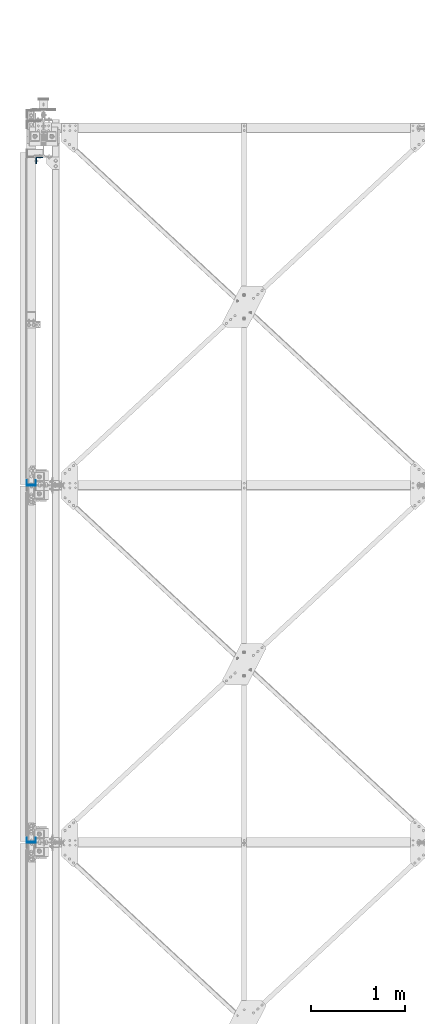
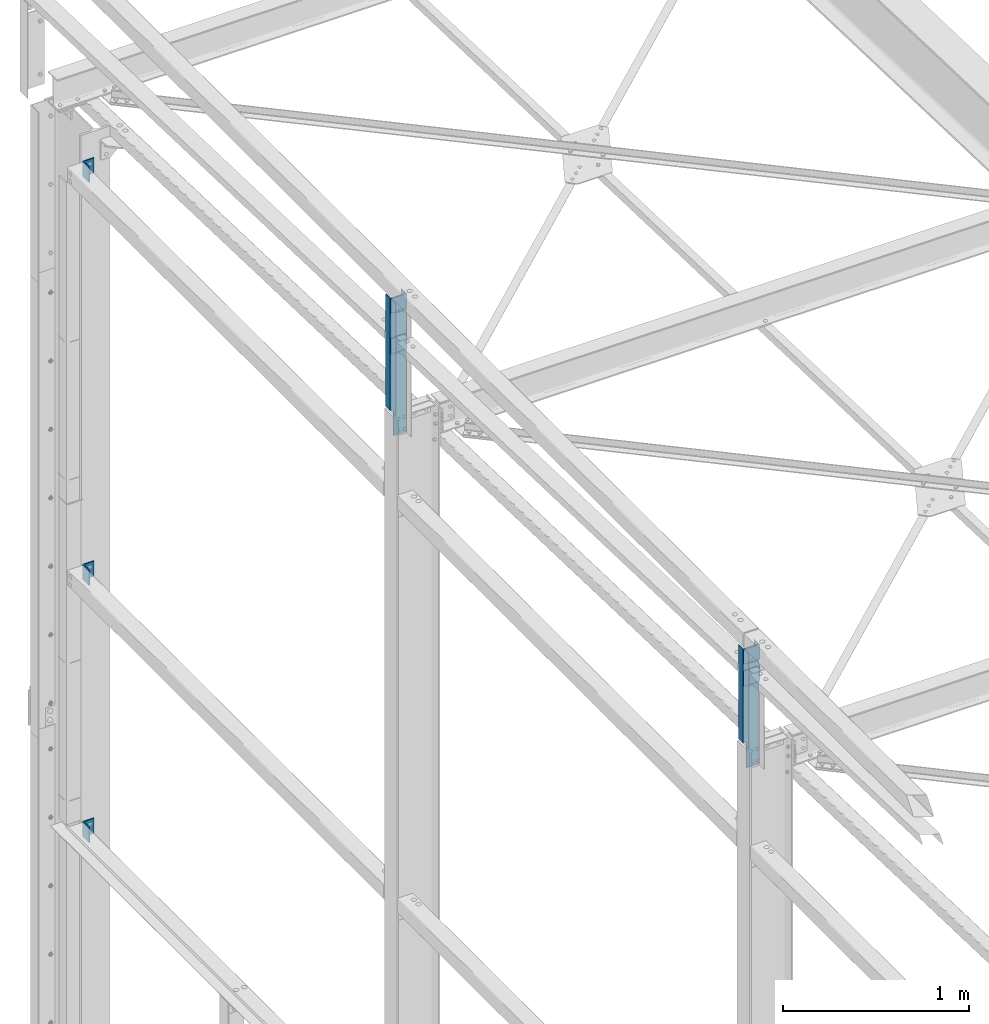
# One storey, part 23 of 496: 9 columns, 9 elements without a shape of their own.
"""IFC2X3 building model written with IfcOpenShell, lengths in millimetres."""

from ifc_helpers import new_model, si_unit, frame, origin_with_axes, origin_2d_with_axis, place, context, subcontext, project, spatial, polyline, rectangle, l_section, u_section, outline, extrude, boolean, material, type_object, element, aggregate, save


model = new_model("IFC2X3")

# Units and contexts
model_context = context("Model", 3, precision=1e-05, world=origin_with_axes())
body_context = subcontext(model_context, "Body", "Model", "MODEL_VIEW")
ifc_project = project(units=[si_unit("LENGTHUNIT", "METRE", prefix="MILLI"), si_unit("AREAUNIT", "SQUARE_METRE"), si_unit("VOLUMEUNIT", "CUBIC_METRE"), si_unit("MASSUNIT", "GRAM", prefix="KILO"), si_unit("TIMEUNIT", "SECOND"), si_unit("PLANEANGLEUNIT", "RADIAN"), si_unit("SOLIDANGLEUNIT", "STERADIAN"), si_unit("THERMODYNAMICTEMPERATUREUNIT", "DEGREE_CELSIUS"), si_unit("LUMINOUSINTENSITYUNIT", "LUMEN")], contexts=[model_context])

# Site, building, storey
site_placement = place(None, origin_with_axes())
site = spatial("IfcSite", under=ifc_project, at=site_placement, CompositionType="ELEMENT")
building_placement = place(site_placement, origin_with_axes())
building = spatial("IfcBuilding", under=site, at=building_placement, Name="Undefined", CompositionType="ELEMENT")
storey_placement = place(building_placement, origin_with_axes())
storey = spatial("IfcBuildingStorey", under=building, at=storey_placement, Name="Undefined", CompositionType="ELEMENT", Elevation=0.0)

# Assembly, column
assembly_1_placement = place(storey_placement, origin_with_axes())
assembly_1 = element("IfcElementAssembly", 1, at=assembly_1_placement, inside=storey, AssemblyPlace="NOTDEFINED", PredefinedType="NOTDEFINED")
ifc_material = material(Name="Undefined/S235-E24")
column_type_1 = type_object("IfcColumnType", PredefinedType="NOTDEFINED")
column_1_placement = place(assembly_1_placement, frame((-45.0000013899306, 14855.0031007332, 7100.00005189506), z_axis=(0.0, 0.0, 1.0), x_axis=(0.0, -1.0, 0.0)))
column_1 = element("IfcColumn", 2, at=column_1_placement, type_object=column_type_1, material=ifc_material, context=body_context, shape_type="SweptSolid", body=[
    extrude(l_section(Depth=70.0, Width=70.0, Thickness=7.0, FilletRadius=9.0, EdgeRadius=4.5, at=origin_2d_with_axis()), frame((0.0, 0.0, 100.0), z_axis=(0.0, 0.0, -1.0), x_axis=(0.0, 1.0, 0.0)), (0.0, 0.0, 1.0), 100.0),
])
aggregate(assembly_1, [column_1])

assembly_2_placement = place(storey_placement, origin_with_axes())
assembly_2 = element("IfcElementAssembly", 3, at=assembly_2_placement, inside=storey, AssemblyPlace="NOTDEFINED", PredefinedType="NOTDEFINED")
column_2_placement = place(assembly_2_placement, frame((-45.0000013899306, 14855.0031513532, 2760.0000275648), z_axis=(0.0, 0.0, 1.0), x_axis=(0.0, -1.0, 0.0)))
column_2 = element("IfcColumn", 4, at=column_2_placement, type_object=column_type_1, material=ifc_material, context=body_context, shape_type="SweptSolid", body=[
    extrude(l_section(Depth=70.0, Width=70.0, Thickness=7.0, FilletRadius=9.0, EdgeRadius=4.5, at=origin_2d_with_axis()), frame((0.0, 0.0, 100.0), z_axis=(0.0, 0.0, -1.0), x_axis=(0.0, 1.0, 0.0)), (0.0, 0.0, 1.0), 100.0),
])
aggregate(assembly_2, [column_2])

assembly_3_placement = place(storey_placement, origin_with_axes())
assembly_3 = element("IfcElementAssembly", 5, at=assembly_3_placement, inside=storey, AssemblyPlace="NOTDEFINED", PredefinedType="NOTDEFINED")
column_3_placement = place(assembly_3_placement, frame((-45.0000013899306, 14855.0031378332, 4450.00002768), z_axis=(0.0, 0.0, 1.0), x_axis=(0.0, -1.0, 0.0)))
column_3 = element("IfcColumn", 6, at=column_3_placement, type_object=column_type_1, material=ifc_material, context=body_context, shape_type="SweptSolid", body=[
    extrude(l_section(Depth=70.0, Width=70.0, Thickness=7.0, FilletRadius=9.0, EdgeRadius=4.5, at=origin_2d_with_axis()), frame((0.0, 0.0, 100.0), z_axis=(0.0, 0.0, -1.0), x_axis=(0.0, 1.0, 0.0)), (0.0, 0.0, 1.0), 100.0),
])
aggregate(assembly_3, [column_3])

assembly_4_placement = place(storey_placement, origin_with_axes())
assembly_4 = element("IfcElementAssembly", 7, at=assembly_4_placement, inside=storey, AssemblyPlace="NOTDEFINED", PredefinedType="NOTDEFINED")
column_type_2 = type_object("IfcColumnType", PredefinedType="NOTDEFINED")
column_4_placement = place(assembly_4_placement, frame((-129.999997908177, 11400.0000000298, 8082.99636005339), z_axis=(0.0, 0.0, 1.0), x_axis=(-1.0, 0.0, 0.0)))
column_4 = element("IfcColumn", 8, at=column_4_placement, type_object=column_type_2, material=ifc_material, context=body_context, shape_type="SweptSolid", body=[
    extrude(rectangle(XDim=6.0, YDim=100.0, at=origin_2d_with_axis()), frame((0.0, 0.0, 100.0), z_axis=(0.0, 0.0, -1.0), x_axis=(0.0, 1.0, 0.0)), (0.0, 0.0, 1.0), 100.0),
])
aggregate(assembly_4, [column_4])

assembly_5_placement = place(storey_placement, origin_with_axes())
assembly_5 = element("IfcElementAssembly", 9, at=assembly_5_placement, inside=storey, AssemblyPlace="NOTDEFINED", PredefinedType="NOTDEFINED")
column_5_placement = place(assembly_5_placement, frame((-129.999997908177, 7600.00000002978, 8202.43), z_axis=(0.0, 0.0, 1.0), x_axis=(-1.0, 0.0, 0.0)))
column_5 = element("IfcColumn", 10, at=column_5_placement, type_object=column_type_2, material=ifc_material, context=body_context, shape_type="SweptSolid", body=[
    extrude(rectangle(XDim=6.0, YDim=100.0, at=origin_2d_with_axis()), frame((0.0, 0.0, 100.0), z_axis=(0.0, 0.0, -1.0), x_axis=(0.0, 1.0, 0.0)), (0.0, 0.0, 1.0), 100.0),
])
aggregate(assembly_5, [column_5])

assembly_6_placement = place(storey_placement, origin_with_axes())
assembly_6 = element("IfcElementAssembly", 11, at=assembly_6_placement, inside=storey, AssemblyPlace="NOTDEFINED", PredefinedType="NOTDEFINED")
column_6_placement = place(assembly_6_placement, frame((-129.999997908177, 7600.00000002978, 8350.0), z_axis=(0.0, 0.0, 1.0), x_axis=(-1.0, 0.0, 0.0)))
column_6 = element("IfcColumn", 12, at=column_6_placement, type_object=column_type_2, material=ifc_material, context=body_context, shape_type="SweptSolid", body=[
    extrude(rectangle(XDim=6.0, YDim=100.0, at=origin_2d_with_axis()), frame((0.0, 0.0, 95.0), z_axis=(0.0, 0.0, -1.0), x_axis=(0.0, 1.0, 0.0)), (0.0, 0.0, 1.0), 95.0),
])
aggregate(assembly_6, [column_6])

assembly_7_placement = place(storey_placement, origin_with_axes())
assembly_7 = element("IfcElementAssembly", 13, at=assembly_7_placement, inside=storey, AssemblyPlace="NOTDEFINED", PredefinedType="NOTDEFINED")
column_7_placement = place(assembly_7_placement, frame((-129.999997908177, 11400.0, 8350.0), z_axis=(0.0, 0.0, 1.0), x_axis=(-1.0, 0.0, 0.0)))
column_7 = element("IfcColumn", 14, at=column_7_placement, type_object=column_type_2, material=ifc_material, context=body_context, shape_type="SweptSolid", body=[
    extrude(rectangle(XDim=6.0, YDim=100.0, at=origin_2d_with_axis()), frame((0.0, 0.0, 95.0), z_axis=(0.0, 0.0, -1.0), x_axis=(0.0, 1.0, 0.0)), (0.0, 0.0, 1.0), 95.0),
])
aggregate(assembly_7, [column_7])

assembly_8_placement = place(storey_placement, origin_with_axes())
assembly_8 = element("IfcElementAssembly", 15, at=assembly_8_placement, inside=storey, AssemblyPlace="NOTDEFINED", PredefinedType="NOTDEFINED")
column_type_3 = type_object("IfcColumnType", PredefinedType="NOTDEFINED")
column_8_placement = place(assembly_8_placement, frame((-130.000001390421, 7628.29999998228, 7655.0002847642), z_axis=(0.0, 0.0, 1.0), x_axis=(1.0, 0.0, 0.0)))
column_8 = element("IfcColumn", 16, at=column_8_placement, type_object=column_type_3, material=ifc_material, context=body_context, shape_type="CSG", body=[
    boolean("DIFFERENCE", extrude(u_section(Depth=100.0, FlangeWidth=50.0, WebThickness=4.0, FlangeThickness=4.0, at=origin_2d_with_axis()), frame((0.0, 0.0, 789.998684463202), z_axis=(0.0, 0.0, -1.0), x_axis=(0.0, 1.0, 0.0)), (0.0, 0.0, 1.0), 790.0), extrude(outline(polyline([(0.0, 0.0), (20.0, 0.0), (19.9999939326024, 170.0), (-6.06739681074941e-06, 170.0), (0.0, 0.0)])), frame((-50.0000000000008, -27.5000000000036, 170.000083651426), z_axis=(0.0, 1.0, 0.0), x_axis=(1.0, 0.0, 0.0)), (0.0, 0.0, 1.0), 55.0)),
])
aggregate(assembly_8, [column_8])

assembly_9_placement = place(storey_placement, origin_with_axes())
assembly_9 = element("IfcElementAssembly", 17, at=assembly_9_placement, inside=storey, AssemblyPlace="NOTDEFINED", PredefinedType="NOTDEFINED")
column_9_placement = place(assembly_9_placement, frame((-130.000001390421, 11428.2999999525, 7535.0013155368), z_axis=(0.0, 0.0, 1.0), x_axis=(1.0, 0.0, 0.0)))
column_9 = element("IfcColumn", 18, at=column_9_placement, type_object=column_type_3, material=ifc_material, context=body_context, shape_type="CSG", body=[
    boolean("DIFFERENCE", extrude(u_section(Depth=100.0, FlangeWidth=50.0, WebThickness=4.0, FlangeThickness=4.0, at=origin_2d_with_axis()), frame((0.0, 0.0, 909.998684463201), z_axis=(0.0, 0.0, -1.0), x_axis=(0.0, 1.0, 0.0)), (0.0, 0.0, 1.0), 910.0), extrude(outline(polyline([(0.0, 0.0), (20.0, 0.0), (19.9999939326024, 170.0), (-6.06739681074941e-06, 170.0), (0.0, 0.0)])), frame((-50.0000000000008, -27.5, 170.0), z_axis=(0.0, 1.0, 0.0), x_axis=(1.0, 0.0, 0.0)), (0.0, 0.0, 1.0), 55.0)),
])
aggregate(assembly_9, [column_9])

save(model, "model.ifc")
